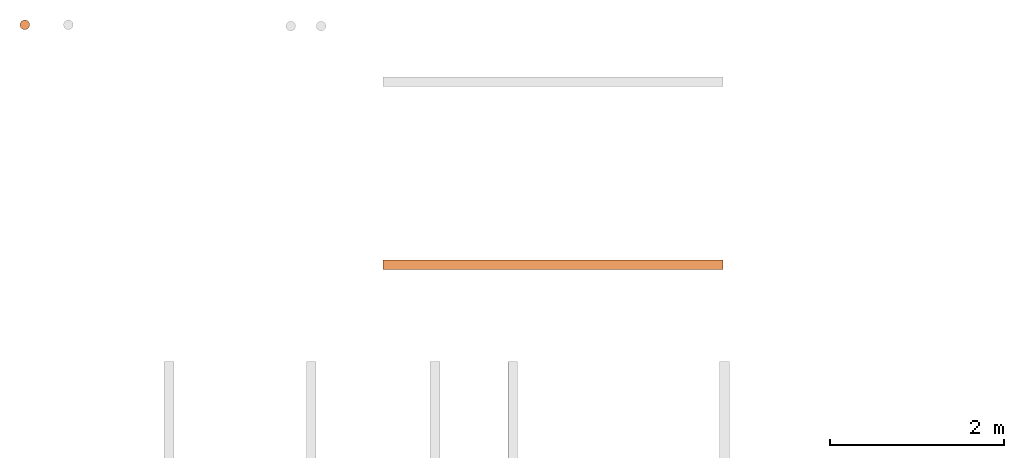
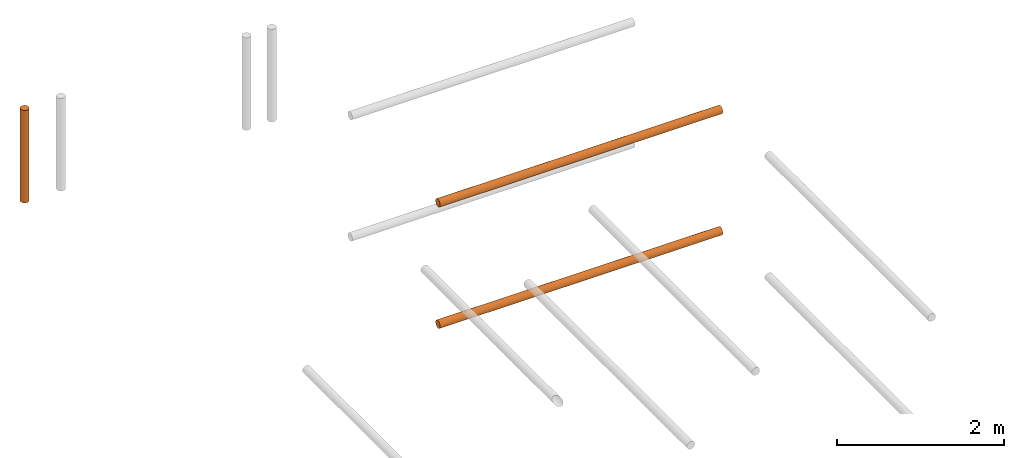
# One storey, part 2 of 5: 3 proxies.
"""IFC2X3 building model written with IfcOpenShell, lengths in metres."""

from ifc_helpers import new_model, entity, si_unit, converted_unit, frame, origin, place, context, subcontext, project, spatial, faceted_brep, material, element, save


model = new_model("IFC2X3")

# Units and contexts
model_context = context("Model", 3, precision=1e-05, world=origin())
body_context = subcontext(model_context, "Body", "Model", "MODEL_VIEW")
ifc_project = project(units=[si_unit("LENGTHUNIT", "METRE"), si_unit("AREAUNIT", "SQUARE_METRE"), si_unit("VOLUMEUNIT", "CUBIC_METRE"), converted_unit("PLANEANGLEUNIT", "DEGREE", entity("IfcPlaneAngleMeasure", 0.0174532925199433), si_unit("PLANEANGLEUNIT", "RADIAN"), dimensions=[0, 0, 0, 0, 0, 0, 0])], contexts=[model_context])

# Site, building, storey
site_placement = place(None, frame((2.0, 7.0, 6.0)))
site = spatial("IfcSite", under=ifc_project, at=site_placement, CompositionType="ELEMENT")
building_placement = place(site_placement, origin())
building = spatial("IfcBuilding", under=site, at=building_placement, Name="de", CompositionType="ELEMENT")
storey_placement = place(building_placement, frame((0.0, 0.0, 4.0)))
storey = spatial("IfcBuildingStorey", under=building, at=storey_placement, CompositionType="ELEMENT", Elevation=4.0)

# Proxies
ifc_material_1 = material()
proxy_1_placement = place(storey_placement, frame((-5.662044050769238, 7.713461170358987, 2.696227106227107)))
element("IfcBuildingElementProxy", 1, at=proxy_1_placement, inside=storey, material=ifc_material_1, context=body_context, shape_type="Brep", body=[
    faceted_brep([(0.05499999999999999, 0.1099999999999995, 9.094947017729283e-16), (0.05499999999999999, 0.1099999999999996, 1.35), (0.04076495251936132, 0.1081259204458984, 1.35), (0.04076495251936132, 0.1081259204458982, 9.094947017729283e-16), (0.04076495251936132, 0.1081259204458982, 9.094947017729283e-16), (0.04076495251936132, 0.1081259204458984, 1.35), (0.02749999999999994, 0.1026313972081437, 1.35), (0.02749999999999994, 0.1026313972081436, 9.094947017729283e-16), (0.02749999999999994, 0.1026313972081436, 9.094947017729283e-16), (0.02749999999999994, 0.1026313972081437, 1.35), (0.01610912703473984, 0.09389087296525969, 1.35), (0.01610912703473984, 0.09389087296525954, 9.094947017729283e-16), (0.01610912703473984, 0.09389087296525954, 9.094947017729283e-16), (0.01610912703473984, 0.09389087296525969, 1.35), (0.007368602791855849, 0.08249999999999959, 1.35), (0.007368602791855849, 0.08249999999999943, 9.094947017729283e-16), (0.007368602791855849, 0.08249999999999943, 9.094947017729283e-16), (0.007368602791855849, 0.08249999999999959, 1.35), (0.001874079554101236, 0.06923504748063825, 1.35), (0.001874079554101236, 0.06923504748063809, 9.094947017729283e-16), (0.001874079554101236, 0.06923504748063809, 9.094947017729283e-16), (0.001874079554101236, 0.06923504748063825, 1.35), (0.0, 0.05499999999999957, 1.35), (0.0, 0.0549999999999994, 9.094947017729283e-16), (0.0, 0.0549999999999994, 9.094947017729283e-16), (0.0, 0.05499999999999957, 1.35), (0.001874079554101257, 0.04076495251936095, 1.35), (0.001874079554101257, 0.04076495251936078, 9.094947017729283e-16), (0.001874079554101257, 0.04076495251936078, 9.094947017729283e-16), (0.001874079554101257, 0.04076495251936095, 1.35), (0.007368602791855913, 0.02749999999999957, 1.35), (0.007368602791855913, 0.0274999999999994, 9.094947017729283e-16), (0.007368602791855913, 0.0274999999999994, 9.094947017729283e-16), (0.007368602791855913, 0.02749999999999957, 1.35), (0.01610912703473991, 0.01610912703473949, 1.35), (0.01610912703473991, 0.01610912703473933, 9.094947017729283e-16), (0.01610912703473991, 0.01610912703473933, 9.094947017729283e-16), (0.01610912703473991, 0.01610912703473949, 1.35), (0.02750000000000004, 0.00736860279185548, 1.35), (0.02750000000000004, 0.007368602791855317, 9.094947017729283e-16), (0.02750000000000004, 0.007368602791855317, 9.094947017729283e-16), (0.02750000000000004, 0.00736860279185548, 1.35), (0.0407649525193614, 0.001874079554100867, 1.35), (0.0407649525193614, 0.001874079554100696, 9.094947017729283e-16), (0.0407649525193614, 0.001874079554100696, 9.094947017729283e-16), (0.0407649525193614, 0.001874079554100867, 1.35), (0.05500000000000003, -3.694822225952521e-16, 1.35), (0.05500000000000003, -5.400124791776761e-16, 9.094947017729283e-16), (0.05500000000000003, -5.400124791776761e-16, 9.094947017729283e-16), (0.05500000000000003, -3.694822225952521e-16, 1.35), (0.06923504748063866, 0.001874079554100881, 1.35), (0.06923504748063866, 0.001874079554100703, 9.094947017729283e-16), (0.06923504748063866, 0.001874079554100703, 9.094947017729283e-16), (0.06923504748063866, 0.001874079554100881, 1.35), (0.08250000000000002, 0.007368602791855515, 1.35), (0.08250000000000002, 0.007368602791855352, 9.094947017729283e-16), (0.08250000000000002, 0.007368602791855352, 9.094947017729283e-16), (0.08250000000000002, 0.007368602791855515, 1.35), (0.09389087296526015, 0.01610912703473954, 1.35), (0.09389087296526015, 0.01610912703473937, 9.094947017729283e-16), (0.09389087296526015, 0.01610912703473937, 9.094947017729283e-16), (0.09389087296526015, 0.01610912703473954, 1.35), (0.1026313972081441, 0.02749999999999964, 1.35), (0.1026313972081441, 0.02749999999999948, 9.094947017729283e-16), (0.1026313972081441, 0.02749999999999948, 9.094947017729283e-16), (0.1026313972081441, 0.02749999999999964, 1.35), (0.1081259204458988, 0.04076495251936101, 1.35), (0.1081259204458988, 0.04076495251936084, 9.094947017729283e-16), (0.1081259204458988, 0.04076495251936084, 9.094947017729283e-16), (0.1081259204458988, 0.04076495251936101, 1.35), (0.11, 0.05499999999999979, 1.35), (0.11, 0.05499999999999954, 9.094947017729283e-16), (0.11, 0.05499999999999954, 9.094947017729283e-16), (0.11, 0.05499999999999979, 1.35), (0.1081259204458988, 0.06923504748063827, 1.35), (0.1081259204458988, 0.06923504748063812, 9.094947017729283e-16), (0.1081259204458988, 0.06923504748063812, 9.094947017729283e-16), (0.1081259204458988, 0.06923504748063827, 1.35), (0.1026313972081441, 0.08249999999999963, 1.35), (0.1026313972081441, 0.08249999999999946, 9.094947017729283e-16), (0.1026313972081441, 0.08249999999999946, 9.094947017729283e-16), (0.1026313972081441, 0.08249999999999963, 1.35), (0.09389087296526012, 0.09389087296525975, 1.35), (0.09389087296526012, 0.09389087296525958, 9.094947017729283e-16), (0.09389087296526012, 0.09389087296525958, 9.094947017729283e-16), (0.09389087296526012, 0.09389087296525975, 1.35), (0.0825, 0.1026313972081438, 1.35), (0.0825, 0.1026313972081436, 9.094947017729283e-16), (0.0825, 0.1026313972081436, 9.094947017729283e-16), (0.0825, 0.1026313972081438, 1.35), (0.06923504748063865, 0.1081259204458984, 1.35), (0.06923504748063865, 0.1081259204458982, 9.094947017729283e-16), (0.06923504748063865, 0.1081259204458982, 9.094947017729283e-16), (0.06923504748063865, 0.1081259204458984, 1.35), (0.05499999999999999, 0.1099999999999996, 1.35), (0.05499999999999999, 0.1099999999999995, 9.094947017729283e-16), (0.11, 0.05499999999999954, 9.094947017729283e-16), (0.1081259204458988, 0.06923504748063812, 9.094947017729283e-16), (0.1026313972081441, 0.08249999999999946, 9.094947017729283e-16), (0.09389087296526012, 0.09389087296525958, 9.094947017729283e-16), (0.0825, 0.1026313972081436, 9.094947017729283e-16), (0.06923504748063865, 0.1081259204458982, 9.094947017729283e-16), (0.05499999999999999, 0.1099999999999995, 9.094947017729283e-16), (0.04076495251936132, 0.1081259204458982, 9.094947017729283e-16), (0.02749999999999994, 0.1026313972081436, 9.094947017729283e-16), (0.01610912703473984, 0.09389087296525954, 9.094947017729283e-16), (0.007368602791855849, 0.08249999999999943, 9.094947017729283e-16), (0.001874079554101236, 0.06923504748063809, 9.094947017729283e-16), (0.0, 0.0549999999999994, 9.094947017729283e-16), (0.001874079554101257, 0.04076495251936078, 9.094947017729283e-16), (0.007368602791855913, 0.0274999999999994, 9.094947017729283e-16), (0.01610912703473991, 0.01610912703473933, 9.094947017729283e-16), (0.02750000000000004, 0.007368602791855317, 9.094947017729283e-16), (0.0407649525193614, 0.001874079554100696, 9.094947017729283e-16), (0.05500000000000003, -5.400124791776761e-16, 9.094947017729283e-16), (0.06923504748063866, 0.001874079554100703, 9.094947017729283e-16), (0.08250000000000002, 0.007368602791855352, 9.094947017729283e-16), (0.09389087296526015, 0.01610912703473937, 9.094947017729283e-16), (0.1026313972081441, 0.02749999999999948, 9.094947017729283e-16), (0.1081259204458988, 0.04076495251936084, 9.094947017729283e-16), (0.11, 0.05499999999999979, 1.35), (0.1081259204458988, 0.04076495251936101, 1.35), (0.1026313972081441, 0.02749999999999964, 1.35), (0.09389087296526015, 0.01610912703473954, 1.35), (0.08250000000000002, 0.007368602791855515, 1.35), (0.06923504748063866, 0.001874079554100881, 1.35), (0.05500000000000003, -3.694822225952521e-16, 1.35), (0.0407649525193614, 0.001874079554100867, 1.35), (0.02750000000000004, 0.00736860279185548, 1.35), (0.01610912703473991, 0.01610912703473949, 1.35), (0.007368602791855913, 0.02749999999999957, 1.35), (0.001874079554101257, 0.04076495251936095, 1.35), (0.0, 0.05499999999999957, 1.35), (0.001874079554101236, 0.06923504748063825, 1.35), (0.007368602791855849, 0.08249999999999959, 1.35), (0.01610912703473984, 0.09389087296525969, 1.35), (0.02749999999999994, 0.1026313972081437, 1.35), (0.04076495251936132, 0.1081259204458984, 1.35), (0.05499999999999999, 0.1099999999999996, 1.35), (0.06923504748063865, 0.1081259204458984, 1.35), (0.0825, 0.1026313972081438, 1.35), (0.09389087296526012, 0.09389087296525975, 1.35), (0.1026313972081441, 0.08249999999999963, 1.35), (0.1081259204458988, 0.06923504748063827, 1.35)], [[[0, 1, 2, 3]], [[4, 5, 6, 7]], [[8, 9, 10, 11]], [[12, 13, 14, 15]], [[16, 17, 18, 19]], [[20, 21, 22, 23]], [[24, 25, 26, 27]], [[28, 29, 30, 31]], [[32, 33, 34, 35]], [[36, 37, 38, 39]], [[40, 41, 42, 43]], [[44, 45, 46, 47]], [[48, 49, 50, 51]], [[52, 53, 54, 55]], [[56, 57, 58, 59]], [[60, 61, 62, 63]], [[64, 65, 66, 67]], [[68, 69, 70, 71]], [[72, 73, 74, 75]], [[76, 77, 78, 79]], [[80, 81, 82, 83]], [[84, 85, 86, 87]], [[88, 89, 90, 91]], [[92, 93, 94, 95]], [[96, 97, 98, 99, 100, 101, 102, 103, 104, 105, 106, 107, 108, 109, 110, 111, 112, 113, 114, 115, 116, 117, 118, 119]], [[120, 121, 122, 123, 124, 125, 126, 127, 128, 129, 130, 131, 132, 133, 134, 135, 136, 137, 138, 139, 140, 141, 142, 143]]], orient=[[False], [False], [False], [False], [False], [False], [False], [False], [False], [False], [False], [False], [False], [False], [False], [False], [False], [False], [False], [False], [False], [False], [False], [False], [False], [False]]),
])
ifc_material_2 = material()
proxy_2_placement = place(storey_placement, frame((-1.492756561293123, 4.960484249084253, 2.833089238362359)))
element("IfcBuildingElementProxy", 2, at=proxy_2_placement, inside=storey, material=ifc_material_2, context=body_context, shape_type="Brep", body=[
    faceted_brep([(3.9, 0.1099999999999998, 0.05500000000000001), (3.9, 0.1081259204458985, 0.04076495251936138), (3.9, 0.1026313972081439, 0.02750000000000001), (3.9, 0.09389087296525989, 0.01610912703473991), (3.9, 0.08249999999999977, 0.007368602791855885), (3.9, 0.06923504748063844, 0.001874079554101257), (3.9, 0.05499999999999979, 0.0), (3.9, 0.04076495251936117, 0.001874079554101236), (3.9, 0.02749999999999982, 0.007368602791855842), (3.9, 0.0161091270347397, 0.01610912703473985), (3.9, 0.007368602791855672, 0.02749999999999994), (3.9, 0.001874079554101023, 0.04076495251936132), (3.9, -2.344791028008331e-16, 0.05499999999999995), (3.9, 0.001874079554100987, 0.06923504748063858), (3.9, 0.007368602791855615, 0.08249999999999996), (3.9, 0.0161091270347396, 0.09389087296526008), (3.9, 0.0274999999999997, 0.1026313972081441), (3.9, 0.04076495251936108, 0.1081259204458988), (3.9, 0.05499999999999976, 0.11), (3.9, 0.0692350474806384, 0.1081259204458988), (3.9, 0.08249999999999974, 0.1026313972081441), (3.9, 0.09389087296525987, 0.09389087296526012), (3.9, 0.1026313972081439, 0.0825), (3.9, 0.1081259204458985, 0.06923504748063866), (0.0, 0.1100000000000002, 0.055), (0.0, 0.108125920445899, 0.06923504748063866), (0.0, 0.1026313972081444, 0.0825), (0.0, 0.09389087296526034, 0.09389087296526012), (0.0, 0.08250000000000023, 0.1026313972081441), (0.0, 0.06923504748063888, 0.1081259204458988), (0.0, 0.05500000000000024, 0.11), (0.0, 0.04076495251936155, 0.1081259204458988), (0.0, 0.02750000000000017, 0.1026313972081441), (0.0, 0.01610912703474008, 0.09389087296526008), (0.0, 0.007368602791856091, 0.08249999999999996), (0.0, 0.001874079554101464, 0.06923504748063858), (0.0, 2.415845301584341e-16, 0.05499999999999995), (0.0, 0.001874079554101499, 0.04076495251936132), (0.0, 0.007368602791856148, 0.02749999999999994), (0.0, 0.01610912703474017, 0.01610912703473985), (0.0, 0.0275000000000003, 0.007368602791855842), (0.0, 0.04076495251936164, 0.001874079554101236), (0.0, 0.05500000000000027, 0.0), (0.0, 0.06923504748063893, 0.001874079554101257), (0.0, 0.08250000000000025, 0.007368602791855885), (0.0, 0.09389087296526037, 0.01610912703473991), (0.0, 0.1026313972081444, 0.02750000000000001), (0.0, 0.108125920445899, 0.04076495251936138), (0.0, 0.05500000000000024, 0.11), (3.9, 0.05499999999999976, 0.11), (3.9, 0.04076495251936108, 0.1081259204458988), (0.0, 0.04076495251936155, 0.1081259204458988), (0.0, 0.04076495251936155, 0.1081259204458988), (3.9, 0.04076495251936108, 0.1081259204458988), (3.9, 0.0274999999999997, 0.1026313972081441), (0.0, 0.02750000000000017, 0.1026313972081441), (0.0, 0.02750000000000017, 0.1026313972081441), (3.9, 0.0274999999999997, 0.1026313972081441), (3.9, 0.0161091270347396, 0.09389087296526008), (0.0, 0.01610912703474008, 0.09389087296526008), (0.0, 0.01610912703474008, 0.09389087296526008), (3.9, 0.0161091270347396, 0.09389087296526008), (3.9, 0.007368602791855615, 0.08249999999999996), (0.0, 0.007368602791856091, 0.08249999999999996), (0.0, 0.007368602791856091, 0.08249999999999996), (3.9, 0.007368602791855615, 0.08249999999999996), (3.9, 0.001874079554100987, 0.06923504748063858), (0.0, 0.001874079554101464, 0.06923504748063858), (0.0, 0.001874079554101464, 0.06923504748063858), (3.9, 0.001874079554100987, 0.06923504748063858), (3.9, -2.344791028008331e-16, 0.05499999999999995), (0.0, 2.415845301584341e-16, 0.05499999999999995), (0.0, 2.415845301584341e-16, 0.05499999999999995), (3.9, -2.344791028008331e-16, 0.05499999999999995), (3.9, 0.001874079554101023, 0.04076495251936132), (0.0, 0.001874079554101499, 0.04076495251936132), (0.0, 0.001874079554101499, 0.04076495251936132), (3.9, 0.001874079554101023, 0.04076495251936132), (3.9, 0.007368602791855672, 0.02749999999999994), (0.0, 0.007368602791856148, 0.02749999999999994), (0.0, 0.007368602791856148, 0.02749999999999994), (3.9, 0.007368602791855672, 0.02749999999999994), (3.9, 0.0161091270347397, 0.01610912703473985), (0.0, 0.01610912703474017, 0.01610912703473985), (0.0, 0.01610912703474017, 0.01610912703473985), (3.9, 0.0161091270347397, 0.01610912703473985), (3.9, 0.02749999999999982, 0.007368602791855842), (0.0, 0.0275000000000003, 0.007368602791855842), (0.0, 0.0275000000000003, 0.007368602791855842), (3.9, 0.02749999999999982, 0.007368602791855842), (3.9, 0.04076495251936117, 0.001874079554101236), (0.0, 0.04076495251936164, 0.001874079554101236), (0.0, 0.04076495251936164, 0.001874079554101236), (3.9, 0.04076495251936117, 0.001874079554101236), (3.9, 0.05499999999999979, 0.0), (0.0, 0.05500000000000027, 0.0), (0.0, 0.05500000000000027, 0.0), (3.9, 0.05499999999999979, 0.0), (3.9, 0.06923504748063844, 0.001874079554101257), (0.0, 0.06923504748063893, 0.001874079554101257), (0.0, 0.06923504748063893, 0.001874079554101257), (3.9, 0.06923504748063844, 0.001874079554101257), (3.9, 0.08249999999999977, 0.007368602791855885), (0.0, 0.08250000000000025, 0.007368602791855885), (0.0, 0.08250000000000025, 0.007368602791855885), (3.9, 0.08249999999999977, 0.007368602791855885), (3.9, 0.09389087296525989, 0.01610912703473991), (0.0, 0.09389087296526037, 0.01610912703473991), (0.0, 0.09389087296526037, 0.01610912703473991), (3.9, 0.09389087296525989, 0.01610912703473991), (3.9, 0.1026313972081439, 0.02750000000000001), (0.0, 0.1026313972081444, 0.02750000000000001), (0.0, 0.1026313972081444, 0.02750000000000001), (3.9, 0.1026313972081439, 0.02750000000000001), (3.9, 0.1081259204458985, 0.04076495251936138), (0.0, 0.108125920445899, 0.04076495251936138), (0.0, 0.108125920445899, 0.04076495251936138), (3.9, 0.1081259204458985, 0.04076495251936138), (3.9, 0.1099999999999998, 0.05500000000000001), (0.0, 0.1100000000000002, 0.055), (0.0, 0.1100000000000002, 0.055), (3.9, 0.1099999999999998, 0.05500000000000001), (3.9, 0.1081259204458985, 0.06923504748063866), (0.0, 0.108125920445899, 0.06923504748063866), (0.0, 0.108125920445899, 0.06923504748063866), (3.9, 0.1081259204458985, 0.06923504748063866), (3.9, 0.1026313972081439, 0.0825), (0.0, 0.1026313972081444, 0.0825), (0.0, 0.1026313972081444, 0.0825), (3.9, 0.1026313972081439, 0.0825), (3.9, 0.09389087296525987, 0.09389087296526012), (0.0, 0.09389087296526034, 0.09389087296526012), (0.0, 0.09389087296526034, 0.09389087296526012), (3.9, 0.09389087296525987, 0.09389087296526012), (3.9, 0.08249999999999974, 0.1026313972081441), (0.0, 0.08250000000000023, 0.1026313972081441), (0.0, 0.08250000000000023, 0.1026313972081441), (3.9, 0.08249999999999974, 0.1026313972081441), (3.9, 0.0692350474806384, 0.1081259204458988), (0.0, 0.06923504748063888, 0.1081259204458988), (0.0, 0.06923504748063888, 0.1081259204458988), (3.9, 0.0692350474806384, 0.1081259204458988), (3.9, 0.05499999999999976, 0.11), (0.0, 0.05500000000000024, 0.11)], [[[0, 1, 2, 3, 4, 5, 6, 7, 8, 9, 10, 11, 12, 13, 14, 15, 16, 17, 18, 19, 20, 21, 22, 23]], [[24, 25, 26, 27, 28, 29, 30, 31, 32, 33, 34, 35, 36, 37, 38, 39, 40, 41, 42, 43, 44, 45, 46, 47]], [[48, 49, 50, 51]], [[52, 53, 54, 55]], [[56, 57, 58, 59]], [[60, 61, 62, 63]], [[64, 65, 66, 67]], [[68, 69, 70, 71]], [[72, 73, 74, 75]], [[76, 77, 78, 79]], [[80, 81, 82, 83]], [[84, 85, 86, 87]], [[88, 89, 90, 91]], [[92, 93, 94, 95]], [[96, 97, 98, 99]], [[100, 101, 102, 103]], [[104, 105, 106, 107]], [[108, 109, 110, 111]], [[112, 113, 114, 115]], [[116, 117, 118, 119]], [[120, 121, 122, 123]], [[124, 125, 126, 127]], [[128, 129, 130, 131]], [[132, 133, 134, 135]], [[136, 137, 138, 139]], [[140, 141, 142, 143]]], orient=[[False], [False], [False], [False], [False], [False], [False], [False], [False], [False], [False], [False], [False], [False], [False], [False], [False], [False], [False], [False], [False], [False], [False], [False], [False], [False]]),
])
ifc_material_3 = material()
proxy_3_placement = place(storey_placement, frame((-1.492756561293123, 4.960484249084253, 1.063089238362359)))
element("IfcBuildingElementProxy", 3, at=proxy_3_placement, inside=storey, material=ifc_material_3, context=body_context, shape_type="Brep", body=[
    faceted_brep([(3.9, 0.1099999999999998, 0.05500000000000001), (3.9, 0.1081259204458985, 0.04076495251936138), (3.9, 0.1026313972081439, 0.02750000000000001), (3.9, 0.09389087296525989, 0.01610912703473991), (3.9, 0.08249999999999977, 0.007368602791855885), (3.9, 0.06923504748063844, 0.001874079554101257), (3.9, 0.05499999999999979, 0.0), (3.9, 0.04076495251936117, 0.001874079554101236), (3.9, 0.02749999999999982, 0.007368602791855842), (3.9, 0.0161091270347397, 0.01610912703473985), (3.9, 0.007368602791855672, 0.02749999999999994), (3.9, 0.001874079554101023, 0.04076495251936132), (3.9, -2.344791028008331e-16, 0.05499999999999995), (3.9, 0.001874079554100987, 0.06923504748063858), (3.9, 0.007368602791855615, 0.08249999999999996), (3.9, 0.0161091270347396, 0.09389087296526008), (3.9, 0.0274999999999997, 0.1026313972081441), (3.9, 0.04076495251936108, 0.1081259204458988), (3.9, 0.05499999999999976, 0.11), (3.9, 0.0692350474806384, 0.1081259204458988), (3.9, 0.08249999999999974, 0.1026313972081441), (3.9, 0.09389087296525987, 0.09389087296526012), (3.9, 0.1026313972081439, 0.0825), (3.9, 0.1081259204458985, 0.06923504748063866), (0.0, 0.1100000000000002, 0.055), (0.0, 0.108125920445899, 0.06923504748063866), (0.0, 0.1026313972081444, 0.0825), (0.0, 0.09389087296526034, 0.09389087296526012), (0.0, 0.08250000000000023, 0.1026313972081441), (0.0, 0.06923504748063888, 0.1081259204458988), (0.0, 0.05500000000000024, 0.11), (0.0, 0.04076495251936155, 0.1081259204458988), (0.0, 0.02750000000000017, 0.1026313972081441), (0.0, 0.01610912703474008, 0.09389087296526008), (0.0, 0.007368602791856091, 0.08249999999999996), (0.0, 0.001874079554101464, 0.06923504748063858), (0.0, 2.415845301584341e-16, 0.05499999999999995), (0.0, 0.001874079554101499, 0.04076495251936132), (0.0, 0.007368602791856148, 0.02749999999999994), (0.0, 0.01610912703474017, 0.01610912703473985), (0.0, 0.0275000000000003, 0.007368602791855842), (0.0, 0.04076495251936164, 0.001874079554101236), (0.0, 0.05500000000000027, 0.0), (0.0, 0.06923504748063893, 0.001874079554101257), (0.0, 0.08250000000000025, 0.007368602791855885), (0.0, 0.09389087296526037, 0.01610912703473991), (0.0, 0.1026313972081444, 0.02750000000000001), (0.0, 0.108125920445899, 0.04076495251936138), (0.0, 0.05500000000000024, 0.11), (3.9, 0.05499999999999976, 0.11), (3.9, 0.04076495251936108, 0.1081259204458988), (0.0, 0.04076495251936155, 0.1081259204458988), (0.0, 0.04076495251936155, 0.1081259204458988), (3.9, 0.04076495251936108, 0.1081259204458988), (3.9, 0.0274999999999997, 0.1026313972081441), (0.0, 0.02750000000000017, 0.1026313972081441), (0.0, 0.02750000000000017, 0.1026313972081441), (3.9, 0.0274999999999997, 0.1026313972081441), (3.9, 0.0161091270347396, 0.09389087296526008), (0.0, 0.01610912703474008, 0.09389087296526008), (0.0, 0.01610912703474008, 0.09389087296526008), (3.9, 0.0161091270347396, 0.09389087296526008), (3.9, 0.007368602791855615, 0.08249999999999996), (0.0, 0.007368602791856091, 0.08249999999999996), (0.0, 0.007368602791856091, 0.08249999999999996), (3.9, 0.007368602791855615, 0.08249999999999996), (3.9, 0.001874079554100987, 0.06923504748063858), (0.0, 0.001874079554101464, 0.06923504748063858), (0.0, 0.001874079554101464, 0.06923504748063858), (3.9, 0.001874079554100987, 0.06923504748063858), (3.9, -2.344791028008331e-16, 0.05499999999999995), (0.0, 2.415845301584341e-16, 0.05499999999999995), (0.0, 2.415845301584341e-16, 0.05499999999999995), (3.9, -2.344791028008331e-16, 0.05499999999999995), (3.9, 0.001874079554101023, 0.04076495251936132), (0.0, 0.001874079554101499, 0.04076495251936132), (0.0, 0.001874079554101499, 0.04076495251936132), (3.9, 0.001874079554101023, 0.04076495251936132), (3.9, 0.007368602791855672, 0.02749999999999994), (0.0, 0.007368602791856148, 0.02749999999999994), (0.0, 0.007368602791856148, 0.02749999999999994), (3.9, 0.007368602791855672, 0.02749999999999994), (3.9, 0.0161091270347397, 0.01610912703473985), (0.0, 0.01610912703474017, 0.01610912703473985), (0.0, 0.01610912703474017, 0.01610912703473985), (3.9, 0.0161091270347397, 0.01610912703473985), (3.9, 0.02749999999999982, 0.007368602791855842), (0.0, 0.0275000000000003, 0.007368602791855842), (0.0, 0.0275000000000003, 0.007368602791855842), (3.9, 0.02749999999999982, 0.007368602791855842), (3.9, 0.04076495251936117, 0.001874079554101236), (0.0, 0.04076495251936164, 0.001874079554101236), (0.0, 0.04076495251936164, 0.001874079554101236), (3.9, 0.04076495251936117, 0.001874079554101236), (3.9, 0.05499999999999979, 0.0), (0.0, 0.05500000000000027, 0.0), (0.0, 0.05500000000000027, 0.0), (3.9, 0.05499999999999979, 0.0), (3.9, 0.06923504748063844, 0.001874079554101257), (0.0, 0.06923504748063893, 0.001874079554101257), (0.0, 0.06923504748063893, 0.001874079554101257), (3.9, 0.06923504748063844, 0.001874079554101257), (3.9, 0.08249999999999977, 0.007368602791855885), (0.0, 0.08250000000000025, 0.007368602791855885), (0.0, 0.08250000000000025, 0.007368602791855885), (3.9, 0.08249999999999977, 0.007368602791855885), (3.9, 0.09389087296525989, 0.01610912703473991), (0.0, 0.09389087296526037, 0.01610912703473991), (0.0, 0.09389087296526037, 0.01610912703473991), (3.9, 0.09389087296525989, 0.01610912703473991), (3.9, 0.1026313972081439, 0.02750000000000001), (0.0, 0.1026313972081444, 0.02750000000000001), (0.0, 0.1026313972081444, 0.02750000000000001), (3.9, 0.1026313972081439, 0.02750000000000001), (3.9, 0.1081259204458985, 0.04076495251936138), (0.0, 0.108125920445899, 0.04076495251936138), (0.0, 0.108125920445899, 0.04076495251936138), (3.9, 0.1081259204458985, 0.04076495251936138), (3.9, 0.1099999999999998, 0.05500000000000001), (0.0, 0.1100000000000002, 0.055), (0.0, 0.1100000000000002, 0.055), (3.9, 0.1099999999999998, 0.05500000000000001), (3.9, 0.1081259204458985, 0.06923504748063866), (0.0, 0.108125920445899, 0.06923504748063866), (0.0, 0.108125920445899, 0.06923504748063866), (3.9, 0.1081259204458985, 0.06923504748063866), (3.9, 0.1026313972081439, 0.0825), (0.0, 0.1026313972081444, 0.0825), (0.0, 0.1026313972081444, 0.0825), (3.9, 0.1026313972081439, 0.0825), (3.9, 0.09389087296525987, 0.09389087296526012), (0.0, 0.09389087296526034, 0.09389087296526012), (0.0, 0.09389087296526034, 0.09389087296526012), (3.9, 0.09389087296525987, 0.09389087296526012), (3.9, 0.08249999999999974, 0.1026313972081441), (0.0, 0.08250000000000023, 0.1026313972081441), (0.0, 0.08250000000000023, 0.1026313972081441), (3.9, 0.08249999999999974, 0.1026313972081441), (3.9, 0.0692350474806384, 0.1081259204458988), (0.0, 0.06923504748063888, 0.1081259204458988), (0.0, 0.06923504748063888, 0.1081259204458988), (3.9, 0.0692350474806384, 0.1081259204458988), (3.9, 0.05499999999999976, 0.11), (0.0, 0.05500000000000024, 0.11)], [[[0, 1, 2, 3, 4, 5, 6, 7, 8, 9, 10, 11, 12, 13, 14, 15, 16, 17, 18, 19, 20, 21, 22, 23]], [[24, 25, 26, 27, 28, 29, 30, 31, 32, 33, 34, 35, 36, 37, 38, 39, 40, 41, 42, 43, 44, 45, 46, 47]], [[48, 49, 50, 51]], [[52, 53, 54, 55]], [[56, 57, 58, 59]], [[60, 61, 62, 63]], [[64, 65, 66, 67]], [[68, 69, 70, 71]], [[72, 73, 74, 75]], [[76, 77, 78, 79]], [[80, 81, 82, 83]], [[84, 85, 86, 87]], [[88, 89, 90, 91]], [[92, 93, 94, 95]], [[96, 97, 98, 99]], [[100, 101, 102, 103]], [[104, 105, 106, 107]], [[108, 109, 110, 111]], [[112, 113, 114, 115]], [[116, 117, 118, 119]], [[120, 121, 122, 123]], [[124, 125, 126, 127]], [[128, 129, 130, 131]], [[132, 133, 134, 135]], [[136, 137, 138, 139]], [[140, 141, 142, 143]]], orient=[[False], [False], [False], [False], [False], [False], [False], [False], [False], [False], [False], [False], [False], [False], [False], [False], [False], [False], [False], [False], [False], [False], [False], [False], [False], [False]]),
])

save(model, "model.ifc")
